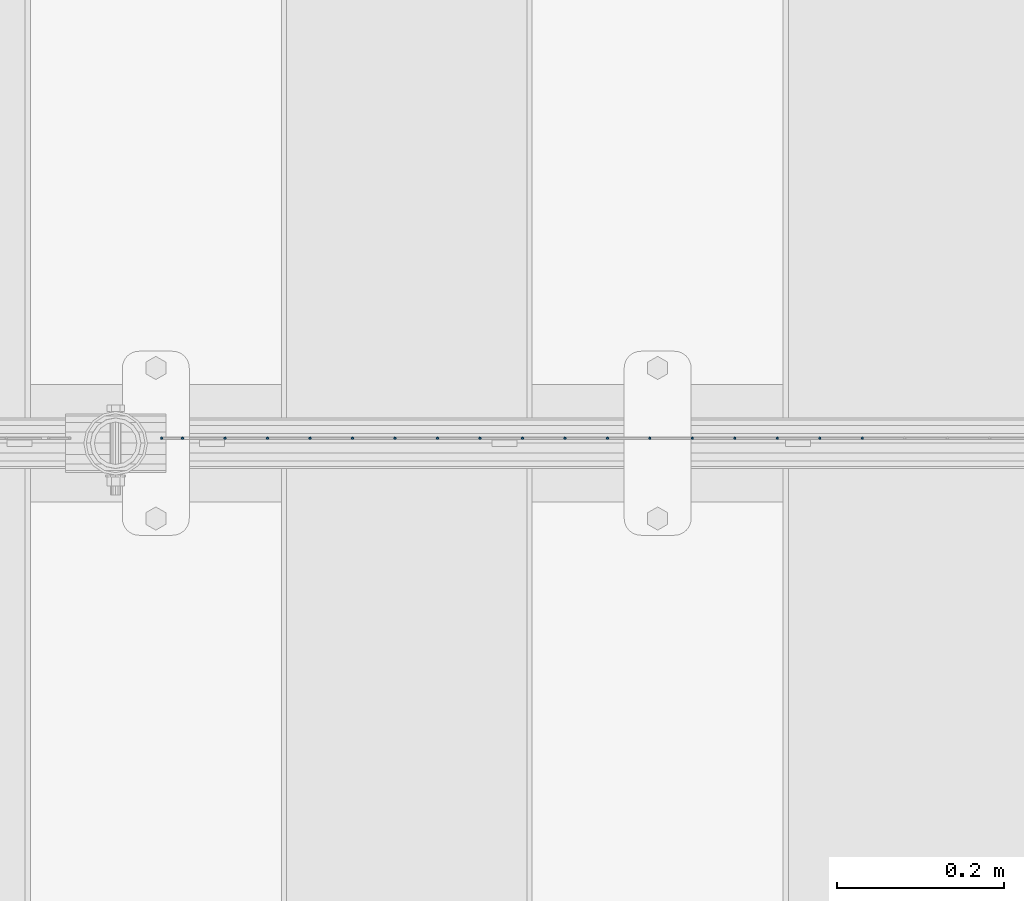
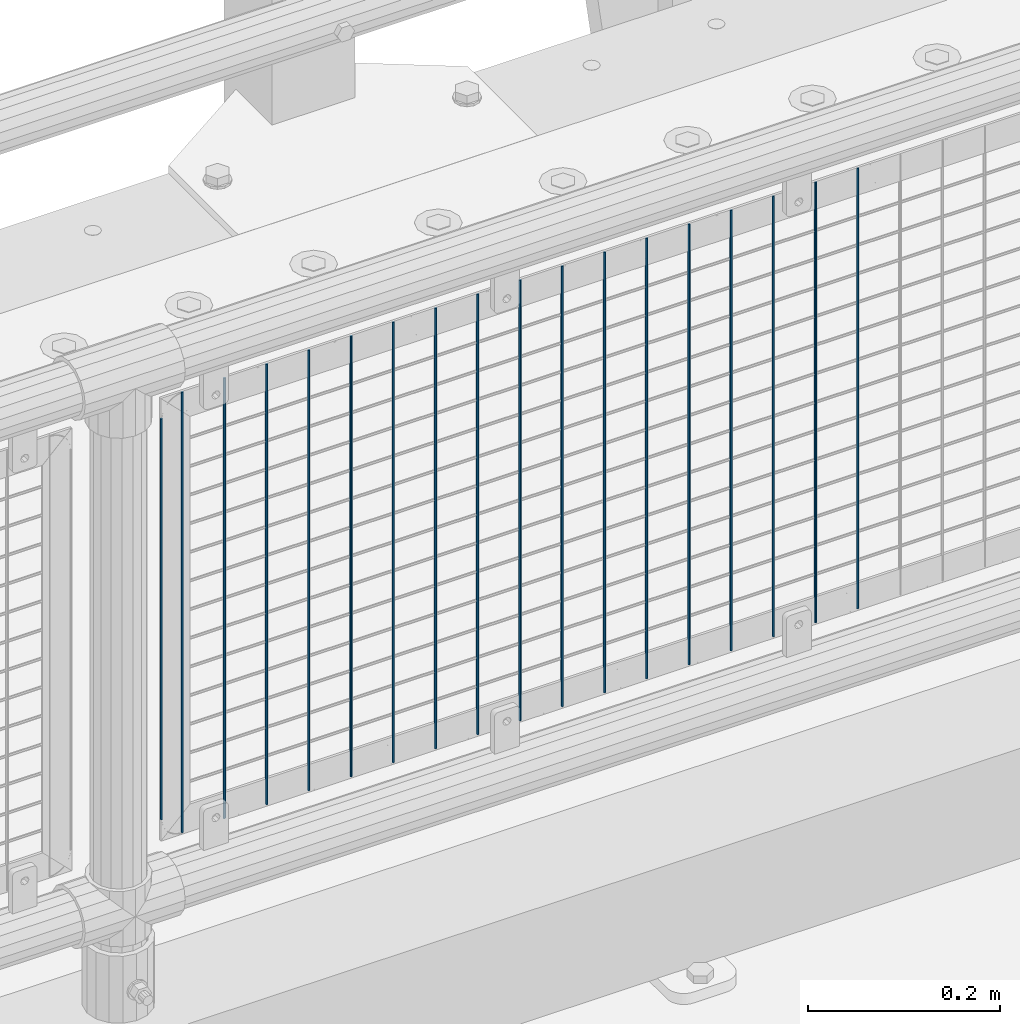
# One storey, part 93 of 270: 18 columns.
"""IFC2X3 building model written with IfcOpenShell, lengths in millimetres."""

from ifc_helpers import new_model, si_unit, frame, origin_with_axes, place, context, subcontext, project, spatial, faceted_brep, material, type_object, element, save


model = new_model("IFC2X3")

# Units and contexts
model_context = context("Model", 3, precision=1e-05, world=origin_with_axes())
body_context = subcontext(model_context, "Body", "Model", "MODEL_VIEW")
ifc_project = project(units=[si_unit("LENGTHUNIT", "METRE", prefix="MILLI"), si_unit("AREAUNIT", "SQUARE_METRE"), si_unit("VOLUMEUNIT", "CUBIC_METRE"), si_unit("MASSUNIT", "GRAM", prefix="KILO"), si_unit("TIMEUNIT", "SECOND"), si_unit("PLANEANGLEUNIT", "RADIAN"), si_unit("SOLIDANGLEUNIT", "STERADIAN"), si_unit("THERMODYNAMICTEMPERATUREUNIT", "DEGREE_CELSIUS"), si_unit("LUMINOUSINTENSITYUNIT", "LUMEN")], contexts=[model_context])

# Site, building, storey
site_placement = place(None, origin_with_axes())
site = spatial("IfcSite", under=ifc_project, at=site_placement, CompositionType="ELEMENT")
building_placement = place(site_placement, origin_with_axes())
building = spatial("IfcBuilding", under=site, at=building_placement, Name="Standard", CompositionType="ELEMENT")
storey_placement = place(building_placement, origin_with_axes())
storey = spatial("IfcBuildingStorey", under=building, at=storey_placement, Name="Undefined", CompositionType="ELEMENT", Elevation=0.0)

# Columns
ifc_material = material(Name="Misc_Undefined")
column_type = type_object("IfcColumnType", Name="D3", PredefinedType="NOTDEFINED")
for number, where, z_axis, x_axis in (
    (1, (12944.688, -16329.5, 353.02), (-1.0, 0.0, 0.0), (0.0, 0.0, 1.0)),
    (2, (12893.895, -16329.5, 353.02), (-1.0, 0.0, 0.0), (0.0, 0.0, 1.0)),
    (3, (12843.102, -16329.5, 353.02), (-1.0, 0.0, 0.0), (0.0, 0.0, 1.0)),
    (4, (12792.309, -16329.5, 353.02), (-1.0, 0.0, 0.0), (0.0, 0.0, 1.0)),
    (5, (12741.516, -16329.5, 353.02), (-1.0, 0.0, 0.0), (0.0, 0.0, 1.0)),
    (6, (12690.723, -16329.5, 353.02), (-1.0, 0.0, 0.0), (0.0, 0.0, 1.0)),
    (7, (12639.93, -16329.5, 353.02), (-1.0, 0.0, 0.0), (0.0, 0.0, 1.0)),
    (8, (12589.137, -16329.5, 353.02), (-1.0, 0.0, 0.0), (0.0, 0.0, 1.0)),
    (9, (12538.344, -16329.5, 353.02), (-1.0, 0.0, 0.0), (0.0, 0.0, 1.0)),
    (10, (12487.551, -16329.5, 353.02), (-1.0, 0.0, 0.0), (0.0, 0.0, 1.0)),
    (11, (12436.758, -16329.5, 353.02), (-1.0, 0.0, 0.0), (0.0, 0.0, 1.0)),
    (12, (12385.965, -16329.5, 353.02), (-1.0, 0.0, 0.0), (0.0, 0.0, 1.0)),
    (13, (12335.172, -16329.5, 353.02), (-1.0, 0.0, 0.0), (0.0, 0.0, 1.0)),
    (14, (12284.379, -16329.5, 353.02), (-1.0, 0.0, 0.0), (0.0, 0.0, 1.0)),
    (15, (12233.586, -16329.5, 353.02), (-1.0, 0.0, 0.0), (0.0, 0.0, 1.0)),
    (16, (12182.793, -16329.5, 353.02), (-1.0, 0.0, 0.0), (0.0, 0.0, 1.0)),
):
    element("IfcColumn", number, at=place(storey_placement, frame(where, z_axis=z_axis, x_axis=x_axis)), inside=storey, type_object=column_type, material=ifc_material, ObjectType="D3", context=body_context, shape_type="Brep", body=[
        faceted_brep([(0.0, -1.5, 0.0), (0.0, -0.75, -1.29903810567669), (560.0, -0.75, -1.29903810567703), (560.0, -1.5, 0.0), (0.0, 0.75, -1.29903810567669), (560.0, 0.75, -1.29903810567703), (0.0, 1.5, 0.0), (560.0, 1.5, 0.0), (0.0, 0.75, 1.29903810567669), (560.0, 0.75, 1.29903810567703), (0.0, -0.75, 1.29903810567669), (560.0, -0.75, 1.29903810567703)], [[[0, 1, 2, 3]], [[1, 4, 5, 2]], [[4, 6, 7, 5]], [[6, 8, 9, 7]], [[8, 10, 11, 9]], [[10, 0, 3, 11]], [[5, 7, 9, 11, 3, 2]], [[10, 8, 6, 4, 1, 0]]]),
    ])
column_1_placement = place(storey_placement, frame((12107.0, -16329.5, 378.02), z_axis=(-1.0, 0.0, 0.0), x_axis=(0.0, 0.0, 1.0)))
element("IfcColumn", 17, at=column_1_placement, inside=storey, type_object=column_type, material=ifc_material, ObjectType="D3", context=body_context, shape_type="Brep", body=[
    faceted_brep([(0.0, -1.5, 0.0), (0.0, -0.75, -1.29903810567669), (510.0, -0.75, -1.29903810567703), (510.0, -1.5, 0.0), (0.0, 0.75, -1.29903810567669), (510.0, 0.75, -1.29903810567703), (0.0, 1.5, 0.0), (510.0, 1.5, 0.0), (0.0, 0.75, 1.29903810567669), (510.0, 0.75, 1.29903810567703), (0.0, -0.75, 1.29903810567669), (510.0, -0.75, 1.29903810567703)], [[[0, 1, 2, 3]], [[1, 4, 5, 2]], [[4, 6, 7, 5]], [[6, 8, 9, 7]], [[8, 10, 11, 9]], [[10, 0, 3, 11]], [[5, 7, 9, 11, 3, 2]], [[10, 8, 6, 4, 1, 0]]]),
])
column_2_placement = place(storey_placement, frame((12132.0, -16329.5, 353.02), z_axis=(-1.0, 0.0, 0.0), x_axis=(0.0, 0.0, 1.0)))
element("IfcColumn", 18, at=column_2_placement, inside=storey, type_object=column_type, material=ifc_material, ObjectType="D3", context=body_context, shape_type="Brep", body=[
    faceted_brep([(0.0, -1.5, 0.0), (0.0, -0.75, -1.29903810567669), (560.0, -0.75, -1.29903810567703), (560.0, -1.5, 0.0), (0.0, 0.75, -1.29903810567669), (560.0, 0.75, -1.29903810567703), (0.0, 1.5, 0.0), (560.0, 1.5, 0.0), (0.0, 0.75, 1.29903810567669), (560.0, 0.75, 1.29903810567703), (0.0, -0.75, 1.29903810567669), (560.0, -0.75, 1.29903810567703)], [[[0, 1, 2, 3]], [[1, 4, 5, 2]], [[4, 6, 7, 5]], [[6, 8, 9, 7]], [[8, 10, 11, 9]], [[10, 0, 3, 11]], [[5, 7, 9, 11, 3, 2]], [[10, 8, 6, 4, 1, 0]]]),
])

save(model, "model.ifc")
